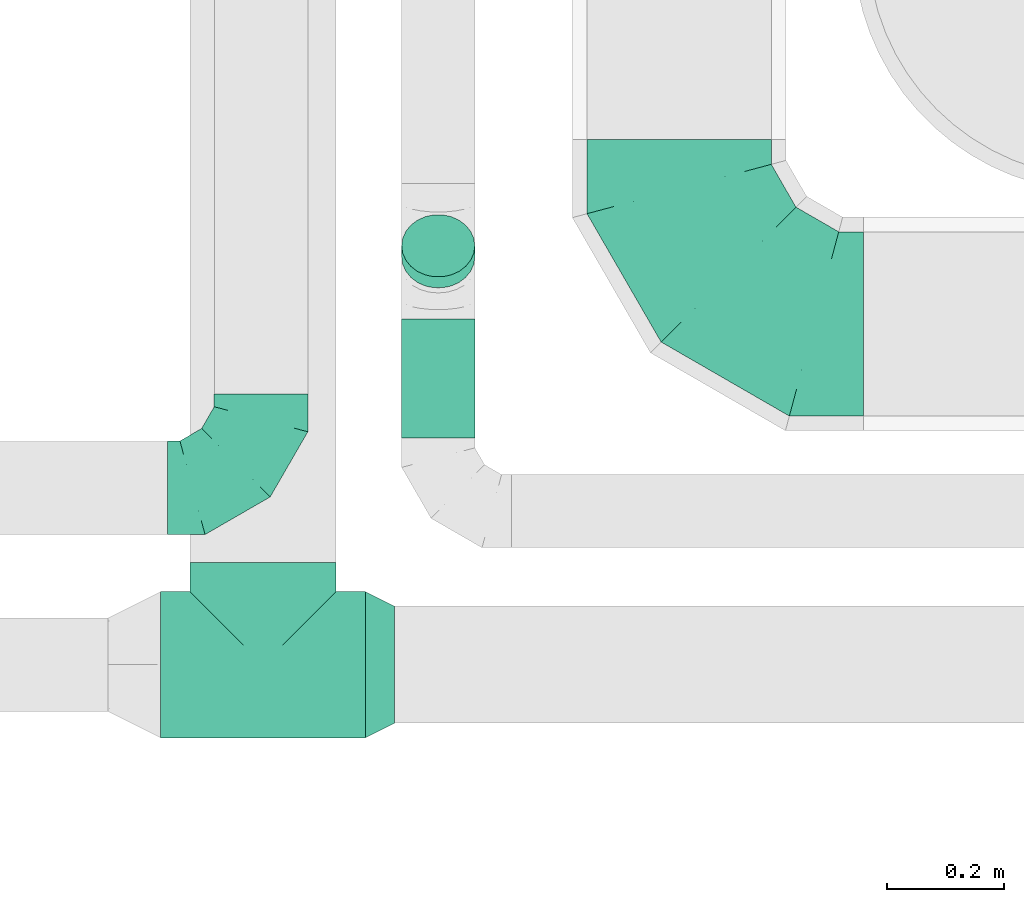
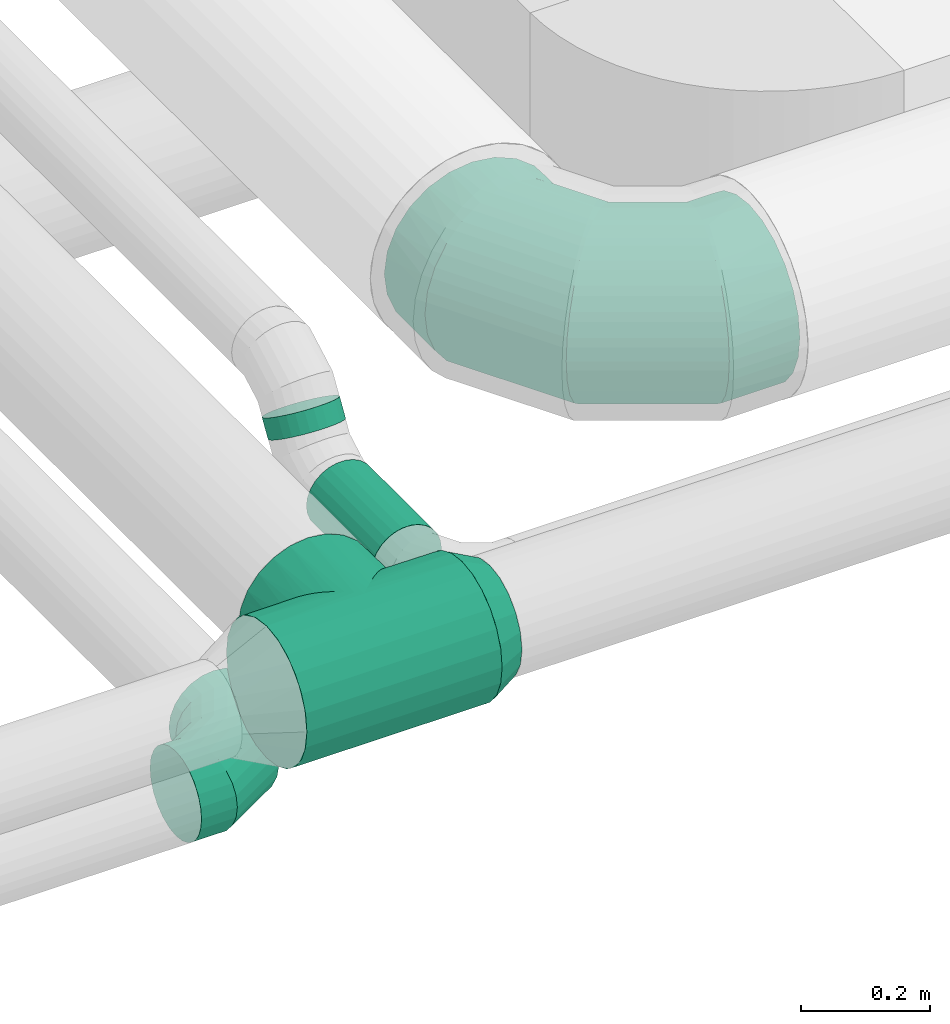
# One storey, part 35 of 92: 4 flow fittings, 2 flow segments.
"""IFC2X3 building model written with IfcOpenShell, lengths in millimetres."""

from ifc_helpers import new_model, entity, si_unit, converted_unit, derived_unit, direction, frame, origin, origin_2d_with_axis, place, context, subcontext, project, spatial, circle, extrude, faceted_brep, source, transform, mapped, material, type_object, type_shapes, element, save


model = new_model("IFC2X3")

# Units and contexts
model_context = context("Model", 3, precision=0.01, world=origin(), true_north=direction((6.12303176911189e-17, 1.0)))
body_context = subcontext(model_context, "Body", "Model", "MODEL_VIEW")
ifc_project = project(units=[si_unit("LENGTHUNIT", "METRE", prefix="MILLI"), si_unit("AREAUNIT", "SQUARE_METRE"), si_unit("VOLUMEUNIT", "CUBIC_METRE"), converted_unit("PLANEANGLEUNIT", "DEGREE", entity("IfcRatioMeasure", 0.0174532925199433), si_unit("PLANEANGLEUNIT", "RADIAN"), dimensions=[0, 0, 0, 0, 0, 0, 0]), si_unit("MASSUNIT", "GRAM", prefix="KILO"), derived_unit("MASSDENSITYUNIT", [(si_unit("MASSUNIT", "GRAM", prefix="KILO"), 1), (si_unit("LENGTHUNIT", "METRE"), -3)]), derived_unit("MOMENTOFINERTIAUNIT", [(si_unit("LENGTHUNIT", "METRE"), 4)]), si_unit("TIMEUNIT", "SECOND"), si_unit("FREQUENCYUNIT", "HERTZ"), si_unit("THERMODYNAMICTEMPERATUREUNIT", "DEGREE_CELSIUS"), derived_unit("THERMALTRANSMITTANCEUNIT", [(si_unit("MASSUNIT", "GRAM", prefix="KILO"), 1), (si_unit("THERMODYNAMICTEMPERATUREUNIT", "KELVIN"), -1), (si_unit("TIMEUNIT", "SECOND"), -3)]), derived_unit("VOLUMETRICFLOWRATEUNIT", [(si_unit("LENGTHUNIT", "METRE"), 3), (si_unit("TIMEUNIT", "SECOND"), -1)]), derived_unit("MASSFLOWRATEUNIT", [(si_unit("MASSUNIT", "GRAM", prefix="KILO"), 1), (si_unit("TIMEUNIT", "SECOND"), -1)]), derived_unit("ROTATIONALFREQUENCYUNIT", [(si_unit("TIMEUNIT", "SECOND"), -1)]), si_unit("ELECTRICCURRENTUNIT", "AMPERE"), si_unit("ELECTRICVOLTAGEUNIT", "VOLT"), si_unit("POWERUNIT", "WATT"), si_unit("FORCEUNIT", "NEWTON", prefix="KILO"), si_unit("ILLUMINANCEUNIT", "LUX"), si_unit("LUMINOUSFLUXUNIT", "LUMEN"), si_unit("LUMINOUSINTENSITYUNIT", "CANDELA"), derived_unit("USERDEFINED", [(si_unit("MASSUNIT", "GRAM", prefix="KILO"), -1), (si_unit("LENGTHUNIT", "METRE"), -2), (si_unit("TIMEUNIT", "SECOND"), 3), (si_unit("LUMINOUSFLUXUNIT", "LUMEN"), 1)]), derived_unit("LINEARVELOCITYUNIT", [(si_unit("LENGTHUNIT", "METRE"), 1), (si_unit("TIMEUNIT", "SECOND"), -1)]), si_unit("PRESSUREUNIT", "PASCAL"), derived_unit("USERDEFINED", [(si_unit("LENGTHUNIT", "METRE"), -2), (si_unit("MASSUNIT", "GRAM", prefix="KILO"), 1), (si_unit("TIMEUNIT", "SECOND"), -2)]), derived_unit("LINEARFORCEUNIT", [(si_unit("MASSUNIT", "GRAM", prefix="KILO"), 1), (si_unit("LENGTHUNIT", "METRE"), 1), (si_unit("TIMEUNIT", "SECOND"), -2), (si_unit("LENGTHUNIT", "METRE"), -1)]), derived_unit("PLANARFORCEUNIT", [(si_unit("MASSUNIT", "GRAM", prefix="KILO"), 1), (si_unit("LENGTHUNIT", "METRE"), 1), (si_unit("TIMEUNIT", "SECOND"), -2), (si_unit("LENGTHUNIT", "METRE"), -2)])], contexts=[model_context])

# Site, building, storey
site_placement = place(None, origin())
site = spatial("IfcSite", under=ifc_project, at=site_placement, CompositionType="ELEMENT")
building_placement = place(site_placement, origin())
building = spatial("IfcBuilding", under=site, at=building_placement, CompositionType="ELEMENT")
storey_placement = place(building_placement, frame((0.0, 0.0, 4200.0)))
storey = spatial("IfcBuildingStorey", under=building, at=storey_placement, CompositionType="ELEMENT", Elevation=4200.0)

# Flow segments
duct_segment_type = type_object("IfcDuctSegmentType", PredefinedType="NOTDEFINED")
flow_segment_1_placement = place(storey_placement, frame((8125.6, 11624.68, 3085.9)))
element("IfcFlowSegment", 1, at=flow_segment_1_placement, inside=storey, type_object=duct_segment_type, context=body_context, shape_type="SweptSolid", body=[
    extrude(circle(Radius=62.5, at=origin_2d_with_axis()), frame((64.1, 0.0, 64.1), z_axis=(0.0, 1.0, 0.0), x_axis=(1.0, 0.0, 0.0)), (0.0, 0.0, 1.0), 203.200433903821),
])
flow_segment_2_placement = place(storey_placement, frame((8125.6, 11879.56, 3175.37)))
element("IfcFlowSegment", 2, at=flow_segment_2_placement, inside=storey, type_object=duct_segment_type, context=body_context, shape_type="SweptSolid", body=[
    extrude(circle(Radius=62.5, at=origin_2d_with_axis()), frame((64.1, 54.87, 34.27), z_axis=(0.0, 0.522828553563816, 0.85243785907148), x_axis=(1.0, 0.0, 0.0)), (0.0, 0.0, 1.0), 36.0227294742767),
])

# Flow fittings
ifc_material = material()
duct_fitting_type_1 = type_object("IfcDuctFittingType", PredefinedType="NOTDEFINED", material=ifc_material)
shared_shape_1 = source(origin(), body_context, "Body", "Brep", [
    faceted_brep([(-160.0, 0.0, -80.0), (-160.0, -20.71, -77.27), (-160.0, -40.0, -69.28), (-160.0, -56.57, -56.57), (-160.0, -69.28, -40.0), (-160.0, -77.27, -20.71), (-160.0, -80.0, 0.0), (-160.0, -77.27, 20.71), (-160.0, -69.28, 40.0), (-160.0, -56.57, 56.57), (-160.0, -40.0, 69.28), (-160.0, -20.71, 77.27), (-160.0, 0.0, 80.0), (-160.0, 20.71, 77.27), (-160.0, 40.0, 69.28), (-160.0, 56.57, 56.57), (-160.0, 69.28, 40.0), (-160.0, 77.27, 20.71), (-160.0, 80.0, 0.0), (-160.0, 77.27, -20.71), (-160.0, 69.28, -40.0), (-160.0, 56.57, -56.57), (-160.0, 40.0, -69.28), (-160.0, 20.71, -77.27), (-122.68, 20.71, 77.27), (-127.85, 40.0, 69.28), (-117.13, 0.0, 80.0), (-132.29, 56.57, 56.57), (-137.83, 77.27, 20.71), (-138.56, 80.0, 0.0), (-135.69, 69.28, 40.0), (-135.69, 69.28, -40.0), (-132.29, 56.57, -56.57), (-137.83, 77.27, -20.71), (-122.68, 20.71, -77.27), (-117.13, 0.0, -80.0), (-127.85, 40.0, -69.28), (-111.58, -20.71, -77.27), (-106.41, -40.0, -69.28), (-101.97, -56.57, -56.57), (-98.56, -69.28, -40.0), (-96.42, -77.27, -20.71), (-95.69, -80.0, 0.0), (-96.42, -77.27, 20.71), (-98.56, -69.28, 40.0), (-101.97, -56.57, 56.57), (-106.41, -40.0, 69.28), (-111.58, -20.71, 77.27), (-58.03, 58.03, 77.27), (-72.15, 72.15, 69.28), (-42.87, 42.87, 80.0), (-84.28, 84.28, 56.57), (-93.59, 93.59, 40.0), (-99.44, 99.44, 20.71), (-101.44, 101.44, 0.0), (-99.44, 99.44, -20.71), (-93.59, 93.59, -40.0), (-84.28, 84.28, -56.57), (-58.03, 58.03, -77.27), (-42.87, 42.87, -80.0), (-72.15, 72.15, -69.28), (-27.71, 27.71, -77.27), (-13.59, 13.59, -69.28), (-1.46, 1.46, -56.57), (7.85, -7.85, -40.0), (13.7, -13.7, -20.71), (15.69, -15.69, 0.0), (13.7, -13.7, 20.71), (7.85, -7.85, 40.0), (-1.46, 1.46, 56.57), (-13.59, 13.59, 69.28), (-27.71, 27.71, 77.27), (-20.71, 122.68, 77.27), (-40.0, 127.85, 69.28), (0.0, 117.13, 80.0), (-56.57, 132.29, 56.57), (-69.28, 135.69, 40.0), (-77.27, 137.83, 20.71), (-80.0, 138.56, 0.0), (-77.27, 137.83, -20.71), (-69.28, 135.69, -40.0), (-56.57, 132.29, -56.57), (-20.71, 122.68, -77.27), (0.0, 117.13, -80.0), (-40.0, 127.85, -69.28), (20.71, 111.58, -77.27), (40.0, 106.41, -69.28), (56.57, 101.97, -56.57), (69.28, 98.56, -40.0), (77.27, 96.42, -20.71), (80.0, 95.69, 0.0), (77.27, 96.42, 20.71), (69.28, 98.56, 40.0), (56.57, 101.97, 56.57), (40.0, 106.41, 69.28), (20.71, 111.58, 77.27), (-20.71, 160.0, -77.27), (-40.0, 160.0, -69.28), (-56.57, 160.0, -56.57), (-69.28, 160.0, -40.0), (-77.27, 160.0, -20.71), (-80.0, 160.0, 0.0), (-77.27, 160.0, 20.71), (-69.28, 160.0, 40.0), (-56.57, 160.0, 56.57), (-40.0, 160.0, 69.28), (-20.71, 160.0, 77.27), (0.0, 160.0, 80.0), (20.71, 160.0, 77.27), (40.0, 160.0, 69.28), (56.57, 160.0, 56.57), (69.28, 160.0, 40.0), (77.27, 160.0, 20.71), (80.0, 160.0, 0.0), (77.27, 160.0, -20.71), (69.28, 160.0, -40.0), (56.57, 160.0, -56.57), (40.0, 160.0, -69.28), (20.71, 160.0, -77.27), (0.0, 160.0, -80.0)], [[[0, 1, 2, 3, 4, 5, 6, 7, 8, 9, 10, 11, 12, 13, 14, 15, 16, 17, 18, 19, 20, 21, 22, 23]], [[24, 25, 14, 13]], [[26, 24, 13, 12]], [[14, 25, 27, 15]], [[28, 29, 18, 17]], [[30, 28, 17, 16]], [[15, 27, 30, 16]], [[20, 31, 32, 21]], [[33, 31, 20, 19]], [[18, 29, 33, 19]], [[34, 35, 0, 23]], [[36, 34, 23, 22]], [[32, 36, 22, 21]], [[1, 0, 35, 37]], [[2, 1, 37, 38]], [[3, 2, 38, 39]], [[5, 4, 40, 41]], [[6, 5, 41, 42]], [[39, 40, 4, 3]], [[6, 42, 43, 7]], [[7, 43, 44, 8]], [[8, 44, 45, 9]], [[9, 45, 46, 10]], [[10, 46, 47, 11]], [[26, 12, 11, 47]], [[48, 49, 25, 24]], [[50, 48, 24, 26]], [[27, 25, 49, 51]], [[52, 53, 28, 30]], [[51, 52, 30, 27]], [[29, 28, 53, 54]], [[55, 56, 31, 33]], [[54, 55, 33, 29]], [[32, 31, 56, 57]], [[58, 59, 35, 34]], [[60, 58, 34, 36]], [[57, 60, 36, 32]], [[37, 35, 59, 61]], [[38, 37, 61, 62]], [[39, 38, 62, 63]], [[41, 40, 64, 65]], [[42, 41, 65, 66]], [[63, 64, 40, 39]], [[43, 42, 66, 67]], [[44, 43, 67, 68]], [[68, 69, 45, 44]], [[46, 45, 69, 70]], [[47, 46, 70, 71]], [[26, 47, 71, 50]], [[72, 73, 49, 48]], [[74, 72, 48, 50]], [[51, 49, 73, 75]], [[76, 77, 53, 52]], [[75, 76, 52, 51]], [[54, 53, 77, 78]], [[79, 80, 56, 55]], [[78, 79, 55, 54]], [[57, 56, 80, 81]], [[82, 83, 59, 58]], [[84, 82, 58, 60]], [[81, 84, 60, 57]], [[61, 59, 83, 85]], [[62, 61, 85, 86]], [[63, 62, 86, 87]], [[65, 64, 88, 89]], [[66, 65, 89, 90]], [[87, 88, 64, 63]], [[67, 66, 90, 91]], [[68, 67, 91, 92]], [[92, 93, 69, 68]], [[70, 69, 93, 94]], [[71, 70, 94, 95]], [[50, 71, 95, 74]], [[96, 97, 98, 99, 100, 101, 102, 103, 104, 105, 106, 107, 108, 109, 110, 111, 112, 113, 114, 115, 116, 117, 118, 119]], [[72, 74, 107, 106]], [[73, 72, 106, 105]], [[75, 73, 105, 104]], [[77, 76, 103, 102]], [[78, 77, 102, 101]], [[75, 104, 103, 76]], [[78, 101, 100, 79]], [[79, 100, 99, 80]], [[80, 99, 98, 81]], [[84, 97, 96, 82]], [[82, 96, 119, 83]], [[84, 81, 98, 97]], [[118, 117, 86, 85]], [[119, 118, 85, 83]], [[116, 87, 86, 117]], [[88, 115, 114, 89]], [[89, 114, 113, 90]], [[115, 88, 87, 116]], [[112, 111, 92, 91]], [[113, 112, 91, 90]], [[111, 110, 93, 92]], [[95, 94, 109, 108]], [[74, 95, 108, 107]], [[110, 109, 94, 93]]]),
])
type_shapes(duct_fitting_type_1, [shared_shape_1])
flow_fitting_1_placement = place(storey_placement, frame((7886.8, 11539.63, 2920.0)))
element("IfcFlowFitting", 3, at=flow_fitting_1_placement, inside=storey, type_object=duct_fitting_type_1, material=ifc_material, context=body_context, shape_type="MappedRepresentation", body=[
    mapped(shared_shape_1, transform((0.0, 0.0, 0.0), scale=1.0)),
])
duct_fitting_type_2 = type_object("IfcDuctFittingType", PredefinedType="NOTDEFINED", material=ifc_material)
shared_shape_2 = source(origin(), body_context, "Body", "Brep", [
    faceted_brep([(-315.0, 0.0, -157.5), (-315.0, -40.76, -152.13), (-315.0, -78.75, -136.4), (-315.0, -111.37, -111.37), (-315.0, -136.4, -78.75), (-315.0, -152.13, -40.76), (-315.0, -157.5, 0.0), (-315.0, -152.13, 40.76), (-315.0, -136.4, 78.75), (-315.0, -111.37, 111.37), (-315.0, -78.75, 136.4), (-315.0, -40.76, 152.13), (-315.0, 0.0, 157.5), (-315.0, 40.76, 152.13), (-315.0, 78.75, 136.4), (-315.0, 111.37, 111.37), (-315.0, 136.4, 78.75), (-315.0, 152.13, 40.76), (-315.0, 157.5, 0.0), (-315.0, 152.13, -40.76), (-315.0, 136.4, -78.75), (-315.0, 111.37, -111.37), (-315.0, 78.75, -136.4), (-315.0, 40.76, -152.13), (-241.52, 40.76, 152.13), (-251.7, 78.75, 136.4), (-230.6, 0.0, 157.5), (-260.44, 111.37, 111.37), (-271.36, 152.13, 40.76), (-272.8, 157.5, 0.0), (-267.14, 136.4, 78.75), (-267.14, 136.4, -78.75), (-260.44, 111.37, -111.37), (-271.36, 152.13, -40.76), (-241.52, 40.76, -152.13), (-230.6, 0.0, -157.5), (-251.7, 78.75, -136.4), (-219.67, -40.76, -152.13), (-209.5, -78.75, -136.4), (-200.75, -111.37, -111.37), (-194.05, -136.4, -78.75), (-189.83, -152.13, -40.76), (-188.39, -157.5, 0.0), (-189.83, -152.13, 40.76), (-194.05, -136.4, 78.75), (-200.75, -111.37, 111.37), (-209.5, -78.75, 136.4), (-219.67, -40.76, 152.13), (-114.25, 114.25, 152.13), (-142.05, 142.05, 136.4), (-84.4, 84.4, 157.5), (-165.93, 165.93, 111.37), (-184.25, 184.25, 78.75), (-195.77, 195.77, 40.76), (-199.7, 199.7, 0.0), (-195.77, 195.77, -40.76), (-184.25, 184.25, -78.75), (-165.93, 165.93, -111.37), (-114.25, 114.25, -152.13), (-84.4, 84.4, -157.5), (-142.05, 142.05, -136.4), (-54.56, 54.56, -152.13), (-26.75, 26.75, -136.4), (-2.88, 2.88, -111.37), (15.45, -15.45, -78.75), (26.97, -26.97, -40.76), (30.89, -30.89, 0.0), (26.97, -26.97, 40.76), (15.45, -15.45, 78.75), (-2.88, 2.88, 111.37), (-26.75, 26.75, 136.4), (-54.56, 54.56, 152.13), (-40.76, 241.52, 152.13), (-78.75, 251.7, 136.4), (0.0, 230.6, 157.5), (-111.37, 260.44, 111.37), (-136.4, 267.14, 78.75), (-152.13, 271.36, 40.76), (-157.5, 272.8, 0.0), (-152.13, 271.36, -40.76), (-136.4, 267.14, -78.75), (-111.37, 260.44, -111.37), (-40.76, 241.52, -152.13), (0.0, 230.6, -157.5), (-78.75, 251.7, -136.4), (40.76, 219.67, -152.13), (78.75, 209.5, -136.4), (111.37, 200.75, -111.37), (136.4, 194.05, -78.75), (152.13, 189.83, -40.76), (157.5, 188.39, 0.0), (152.13, 189.83, 40.76), (136.4, 194.05, 78.75), (111.37, 200.75, 111.37), (78.75, 209.5, 136.4), (40.76, 219.67, 152.13), (-40.76, 315.0, -152.13), (-78.75, 315.0, -136.4), (-111.37, 315.0, -111.37), (-136.4, 315.0, -78.75), (-152.13, 315.0, -40.76), (-157.5, 315.0, 0.0), (-152.13, 315.0, 40.76), (-136.4, 315.0, 78.75), (-111.37, 315.0, 111.37), (-78.75, 315.0, 136.4), (-40.76, 315.0, 152.13), (0.0, 315.0, 157.5), (40.76, 315.0, 152.13), (78.75, 315.0, 136.4), (111.37, 315.0, 111.37), (136.4, 315.0, 78.75), (152.13, 315.0, 40.76), (157.5, 315.0, 0.0), (152.13, 315.0, -40.76), (136.4, 315.0, -78.75), (111.37, 315.0, -111.37), (78.75, 315.0, -136.4), (40.76, 315.0, -152.13), (0.0, 315.0, -157.5)], [[[0, 1, 2, 3, 4, 5, 6, 7, 8, 9, 10, 11, 12, 13, 14, 15, 16, 17, 18, 19, 20, 21, 22, 23]], [[24, 25, 14, 13]], [[26, 24, 13, 12]], [[14, 25, 27, 15]], [[28, 29, 18, 17]], [[30, 28, 17, 16]], [[15, 27, 30, 16]], [[20, 31, 32, 21]], [[33, 31, 20, 19]], [[18, 29, 33, 19]], [[34, 35, 0, 23]], [[36, 34, 23, 22]], [[32, 36, 22, 21]], [[1, 0, 35, 37]], [[2, 1, 37, 38]], [[38, 39, 3, 2]], [[5, 4, 40, 41]], [[6, 5, 41, 42]], [[39, 40, 4, 3]], [[6, 42, 43, 7]], [[7, 43, 44, 8]], [[8, 44, 45, 9]], [[9, 45, 46, 10]], [[10, 46, 47, 11]], [[26, 12, 11, 47]], [[48, 49, 25, 24]], [[50, 48, 24, 26]], [[27, 25, 49, 51]], [[52, 53, 28, 30]], [[51, 52, 30, 27]], [[29, 28, 53, 54]], [[55, 56, 31, 33]], [[54, 55, 33, 29]], [[32, 31, 56, 57]], [[58, 59, 35, 34]], [[60, 58, 34, 36]], [[57, 60, 36, 32]], [[37, 35, 59, 61]], [[38, 37, 61, 62]], [[39, 38, 62, 63]], [[41, 40, 64, 65]], [[42, 41, 65, 66]], [[63, 64, 40, 39]], [[43, 42, 66, 67]], [[44, 43, 67, 68]], [[68, 69, 45, 44]], [[46, 45, 69, 70]], [[47, 46, 70, 71]], [[26, 47, 71, 50]], [[72, 73, 49, 48]], [[74, 72, 48, 50]], [[51, 49, 73, 75]], [[76, 77, 53, 52]], [[75, 76, 52, 51]], [[54, 53, 77, 78]], [[79, 80, 56, 55]], [[78, 79, 55, 54]], [[57, 56, 80, 81]], [[82, 83, 59, 58]], [[84, 82, 58, 60]], [[81, 84, 60, 57]], [[61, 59, 83, 85]], [[62, 61, 85, 86]], [[63, 62, 86, 87]], [[65, 64, 88, 89]], [[66, 65, 89, 90]], [[87, 88, 64, 63]], [[67, 66, 90, 91]], [[68, 67, 91, 92]], [[92, 93, 69, 68]], [[70, 69, 93, 94]], [[71, 70, 94, 95]], [[50, 71, 95, 74]], [[96, 97, 98, 99, 100, 101, 102, 103, 104, 105, 106, 107, 108, 109, 110, 111, 112, 113, 114, 115, 116, 117, 118, 119]], [[106, 105, 73, 72]], [[107, 106, 72, 74]], [[75, 73, 105, 104]], [[77, 76, 103, 102]], [[78, 77, 102, 101]], [[104, 103, 76, 75]], [[78, 101, 100, 79]], [[79, 100, 99, 80]], [[98, 81, 80, 99]], [[84, 97, 96, 82]], [[82, 96, 119, 83]], [[97, 84, 81, 98]], [[83, 119, 118, 85]], [[85, 118, 117, 86]], [[116, 87, 86, 117]], [[88, 115, 114, 89]], [[89, 114, 113, 90]], [[115, 88, 87, 116]], [[91, 90, 113, 112]], [[92, 91, 112, 111]], [[111, 110, 93, 92]], [[95, 94, 109, 108]], [[74, 95, 108, 107]], [[110, 109, 94, 93]]]),
])
type_shapes(duct_fitting_type_2, [shared_shape_2])
flow_fitting_2_placement = place(storey_placement, frame((8601.41, 11819.68, 3292.5), z_axis=(0.0, 0.0, 1.0), x_axis=(0.0, -1.0, 0.0)))
element("IfcFlowFitting", 4, at=flow_fitting_2_placement, inside=storey, type_object=duct_fitting_type_2, material=ifc_material, context=body_context, shape_type="MappedRepresentation", body=[
    mapped(shared_shape_2, transform((0.0, 0.0, 0.0), scale=1.0)),
])
duct_fitting_type_3 = type_object("IfcDuctFittingType", PredefinedType="NOTDEFINED", material=ifc_material)
shared_shape_3 = source(origin(), body_context, "Body", "Brep", [
    faceted_brep([(50.0, -73.47, -101.13), (50.0, -38.63, -118.88), (50.0, 0.0, -125.0), (50.0, 38.63, -118.88), (50.0, 73.47, -101.13), (50.0, 101.13, -73.47), (50.0, 118.88, -38.63), (50.0, 125.0, 0.0), (50.0, 118.88, 38.63), (50.0, 101.13, 73.47), (50.0, 73.47, 101.13), (50.0, 38.63, 118.88), (50.0, 0.0, 125.0), (50.0, -38.63, 118.88), (50.0, -73.47, 101.13), (50.0, -101.13, 73.47), (50.0, -118.88, 38.63), (50.0, -125.0, 0.0), (50.0, -118.88, -38.63), (50.0, -101.13, -73.47), (0.0, 30.9, -95.11), (0.0, 0.0, -100.0), (0.0, -30.9, -95.11), (0.0, -58.78, -80.9), (0.0, -80.9, -58.78), (0.0, -95.11, -30.9), (0.0, -100.0, 0.0), (0.0, -95.11, 30.9), (0.0, -80.9, 58.78), (0.0, -58.78, 80.9), (0.0, -30.9, 95.11), (0.0, 0.0, 100.0), (0.0, 30.9, 95.11), (0.0, 58.78, 80.9), (0.0, 80.9, 58.78), (0.0, 95.11, 30.9), (0.0, 100.0, 0.0), (0.0, 95.11, -30.9), (0.0, 80.9, -58.78), (0.0, 58.78, -80.9)], [[[0, 1, 2, 3, 4, 5, 6, 7, 8, 9, 10, 11, 12, 13, 14, 15, 16, 17, 18, 19]], [[20, 21, 22, 23, 24, 25, 26, 27, 28, 29, 30, 31, 32, 33, 34, 35, 36, 37, 38, 39]], [[35, 34, 9, 8]], [[36, 35, 8, 7]], [[34, 33, 10, 9]], [[10, 33, 32, 11]], [[11, 32, 31, 12]], [[30, 29, 14, 13]], [[31, 30, 13, 12]], [[29, 28, 15, 14]], [[15, 28, 27, 16]], [[16, 27, 26, 17]], [[25, 24, 19, 18]], [[26, 25, 18, 17]], [[24, 23, 0, 19]], [[0, 23, 22, 1]], [[1, 22, 21, 2]], [[20, 39, 4, 3]], [[21, 20, 3, 2]], [[39, 38, 5, 4]], [[5, 38, 37, 6]], [[6, 37, 36, 7]]]),
])
type_shapes(duct_fitting_type_3, [shared_shape_3])
flow_fitting_3_placement = place(storey_placement, frame((8115.09, 11237.19, 3300.0), z_axis=(0.0, 0.0, 1.0), x_axis=(-1.0, 0.0, 0.0)))
element("IfcFlowFitting", 5, at=flow_fitting_3_placement, inside=storey, type_object=duct_fitting_type_3, material=ifc_material, context=body_context, shape_type="MappedRepresentation", body=[
    mapped(shared_shape_3, transform((0.0, 0.0, 0.0), scale=1.0)),
])
duct_fitting_type_4 = type_object("IfcDuctFittingType", PredefinedType="NOTDEFINED", material=ifc_material)
shared_shape_4 = source(origin(), body_context, "Body", "Brep", [
    faceted_brep([(22.44, -22.44, -122.97), (175.0, 0.0, -125.0), (175.0, -32.35, -120.74), (175.0, -62.5, -108.25), (75.83, -75.83, -99.37), (65.72, -65.72, -106.33), (175.0, -88.39, -88.39), (55.24, -55.24, -112.13), (11.24, -11.24, -124.49), (0.0, 0.0, -125.0), (-11.24, -11.24, -124.49), (-175.0, 0.0, -125.0), (44.49, -44.49, -116.81), (33.54, -33.54, -120.42), (175.0, -108.25, -62.5), (102.86, -102.86, -71.03), (175.0, -120.74, -32.35), (116.36, -116.36, -45.66), (175.0, -114.5, -47.43), (123.99, -123.99, -15.84), (175.0, -125.0, 0.0), (125.0, -125.0, 0.0), (-123.99, -123.99, -15.84), (-125.0, -125.0, 0.0), (-175.0, -125.0, 0.0), (175.0, -122.87, -16.18), (110.21, -110.21, -58.98), (121.05, -121.05, -31.19), (94.55, -94.55, -81.76), (85.49, -85.49, -91.2), (123.99, -123.99, 15.84), (-123.99, -123.99, 15.84), (175.0, -114.5, 47.43), (175.0, -108.25, 62.5), (110.21, -110.21, 58.98), (175.0, -120.74, 32.35), (121.05, -121.05, 31.19), (175.0, -122.87, 16.18), (102.86, -102.86, 71.03), (175.0, -88.39, 88.39), (116.36, -116.36, 45.66), (94.55, -94.55, 81.76), (85.49, -85.49, 91.2), (75.83, -75.83, 99.37), (65.72, -65.72, 106.33), (175.0, -62.5, 108.25), (55.24, -55.24, 112.13), (175.0, -32.35, 120.74), (22.44, -22.44, 122.97), (175.0, 0.0, 125.0), (44.49, -44.49, 116.81), (33.54, -33.54, 120.42), (11.24, -11.24, 124.49), (0.0, 0.0, 125.0), (-11.24, -11.24, 124.49), (-175.0, 0.0, 125.0), (32.35, -175.0, -120.74), (62.5, -175.0, -108.25), (88.39, -175.0, -88.39), (108.25, -175.0, -62.5), (114.5, -175.0, -47.43), (120.74, -175.0, -32.35), (122.87, -175.0, -16.18), (125.0, -175.0, 0.0), (122.87, -175.0, 16.18), (120.74, -175.0, 32.35), (114.5, -175.0, 47.43), (108.25, -175.0, 62.5), (88.39, -175.0, 88.39), (62.5, -175.0, 108.25), (32.35, -175.0, 120.74), (0.0, -175.0, 125.0), (-32.35, -175.0, 120.74), (-62.5, -175.0, 108.25), (-88.39, -175.0, 88.39), (-108.25, -175.0, 62.5), (-114.5, -175.0, 47.43), (-120.74, -175.0, 32.35), (-122.87, -175.0, 16.18), (-125.0, -175.0, 0.0), (-122.87, -175.0, -16.18), (-120.74, -175.0, -32.35), (-114.5, -175.0, -47.43), (-108.25, -175.0, -62.5), (-88.39, -175.0, -88.39), (-62.5, -175.0, -108.25), (-32.35, -175.0, -120.74), (0.0, -175.0, -125.0), (-22.44, -22.44, -122.97), (-75.83, -75.83, -99.37), (-65.72, -65.72, -106.33), (-55.24, -55.24, -112.13), (-44.49, -44.49, -116.81), (-33.54, -33.54, -120.42), (-102.86, -102.86, -71.03), (-116.36, -116.36, -45.66), (-110.21, -110.21, -58.98), (-121.05, -121.05, -31.19), (-94.55, -94.55, -81.76), (-85.49, -85.49, -91.2), (-110.21, -110.21, 58.98), (-121.05, -121.05, 31.19), (-102.86, -102.86, 71.03), (-116.36, -116.36, 45.66), (-94.55, -94.55, 81.76), (-85.49, -85.49, 91.2), (-75.83, -75.83, 99.37), (-65.72, -65.72, 106.33), (-55.24, -55.24, 112.13), (-22.44, -22.44, 122.97), (-44.49, -44.49, 116.81), (-33.54, -33.54, 120.42), (-175.0, -32.35, -120.74), (-175.0, -62.5, -108.25), (-175.0, -88.39, -88.39), (-175.0, -108.25, -62.5), (-175.0, -114.5, -47.43), (-175.0, -120.74, -32.35), (-175.0, -122.87, -16.18), (-175.0, -122.87, 16.18), (-175.0, -120.74, 32.35), (-175.0, -114.5, 47.43), (-175.0, -108.25, 62.5), (-175.0, -88.39, 88.39), (-175.0, -62.5, 108.25), (-175.0, -32.35, 120.74), (-175.0, 32.35, 120.74), (-175.0, 62.5, 108.25), (-175.0, 88.39, 88.39), (-175.0, 108.25, 62.5), (-175.0, 120.74, 32.35), (-175.0, 125.0, 0.0), (-175.0, 120.74, -32.35), (-175.0, 108.25, -62.5), (-175.0, 88.39, -88.39), (-175.0, 62.5, -108.25), (-175.0, 32.35, -120.74), (175.0, 32.35, -120.74), (175.0, 62.5, -108.25), (175.0, 88.39, -88.39), (175.0, 108.25, -62.5), (175.0, 120.74, -32.35), (175.0, 125.0, 0.0), (175.0, 120.74, 32.35), (175.0, 108.25, 62.5), (175.0, 88.39, 88.39), (175.0, 62.5, 108.25), (175.0, 32.35, 120.74)], [[[0, 1, 2]], [[3, 4, 5]], [[4, 3, 6]], [[2, 3, 7]], [[5, 7, 3]], [[8, 9, 1]], [[9, 10, 11]], [[0, 8, 1]], [[12, 13, 2]], [[7, 12, 2]], [[0, 2, 13]], [[14, 15, 6]], [[16, 17, 18]], [[19, 20, 21]], [[22, 23, 24]], [[20, 19, 25]], [[26, 18, 17]], [[27, 16, 25]], [[28, 29, 6]], [[15, 28, 6]], [[27, 25, 19]], [[26, 14, 18]], [[27, 17, 16]], [[15, 14, 26]], [[6, 29, 4]], [[30, 21, 20]], [[23, 31, 24]], [[32, 33, 34]], [[35, 36, 37]], [[38, 33, 39]], [[40, 35, 32]], [[30, 37, 36]], [[40, 36, 35]], [[38, 34, 33]], [[41, 38, 39]], [[32, 34, 40]], [[30, 20, 37]], [[39, 42, 41]], [[42, 39, 43]], [[44, 43, 45]], [[46, 45, 47]], [[45, 46, 44]], [[39, 45, 43]], [[48, 47, 49]], [[50, 46, 47]], [[51, 50, 47]], [[52, 48, 49]], [[53, 52, 49]], [[54, 53, 55]], [[51, 47, 48]], [[56, 57, 58, 59, 60, 61, 62, 63, 64, 65, 66, 67, 68, 69, 70, 71, 72, 73, 74, 75, 76, 77, 78, 79, 80, 81, 82, 83, 84, 85, 86, 87]], [[48, 71, 70]], [[69, 43, 44]], [[43, 69, 68]], [[70, 69, 46]], [[44, 46, 69]], [[52, 53, 71]], [[48, 52, 71]], [[50, 51, 70]], [[46, 50, 70]], [[48, 70, 51]], [[67, 38, 68]], [[65, 40, 66]], [[30, 63, 21]], [[63, 30, 64]], [[34, 66, 40]], [[36, 65, 64]], [[41, 42, 68]], [[38, 41, 68]], [[36, 64, 30]], [[34, 67, 66]], [[36, 40, 65]], [[38, 67, 34]], [[68, 42, 43]], [[19, 21, 63]], [[60, 59, 26]], [[62, 61, 27]], [[15, 59, 58]], [[17, 61, 60]], [[19, 62, 27]], [[17, 27, 61]], [[15, 26, 59]], [[28, 15, 58]], [[60, 26, 17]], [[19, 63, 62]], [[58, 29, 28]], [[29, 58, 4]], [[5, 4, 57]], [[7, 57, 56]], [[57, 7, 5]], [[58, 57, 4]], [[0, 56, 87]], [[12, 7, 56]], [[13, 12, 56]], [[8, 0, 87]], [[9, 8, 87]], [[13, 56, 0]], [[88, 87, 86]], [[85, 89, 90]], [[89, 85, 84]], [[86, 85, 91]], [[90, 91, 85]], [[10, 9, 87]], [[88, 10, 87]], [[92, 93, 86]], [[91, 92, 86]], [[88, 86, 93]], [[83, 94, 84]], [[81, 95, 82]], [[22, 79, 23]], [[79, 22, 80]], [[96, 82, 95]], [[97, 81, 80]], [[98, 99, 84]], [[94, 98, 84]], [[97, 80, 22]], [[96, 83, 82]], [[97, 95, 81]], [[94, 83, 96]], [[84, 99, 89]], [[31, 23, 79]], [[76, 75, 100]], [[77, 101, 78]], [[102, 75, 74]], [[103, 77, 76]], [[31, 78, 101]], [[103, 101, 77]], [[102, 100, 75]], [[104, 102, 74]], [[76, 100, 103]], [[31, 79, 78]], [[74, 105, 104]], [[105, 74, 106]], [[107, 106, 73]], [[108, 73, 72]], [[73, 108, 107]], [[74, 73, 106]], [[109, 72, 71]], [[110, 108, 72]], [[111, 110, 72]], [[54, 109, 71]], [[53, 54, 71]], [[111, 72, 109]], [[11, 112, 113, 114, 115, 116, 117, 118, 24, 119, 120, 121, 122, 123, 124, 125, 55, 126, 127, 128, 129, 130, 131, 132, 133, 134, 135, 136]], [[137, 138, 139, 140, 141, 142, 143, 144, 145, 146, 147, 49, 47, 45, 39, 33, 32, 35, 37, 20, 25, 16, 18, 14, 6, 3, 2, 1]], [[53, 49, 147, 126, 55]], [[127, 126, 147, 146]], [[146, 145, 128, 127]], [[129, 128, 145, 144]], [[130, 129, 144, 143]], [[131, 130, 143, 142]], [[132, 131, 142, 141]], [[133, 132, 141, 140]], [[140, 139, 134, 133]], [[135, 134, 139, 138]], [[136, 135, 138, 137]], [[9, 11, 136, 137, 1]], [[93, 92, 112]], [[88, 93, 112]], [[10, 88, 11]], [[88, 112, 11]], [[112, 92, 91]], [[112, 91, 113]], [[113, 90, 89]], [[90, 113, 91]], [[113, 89, 114]], [[98, 94, 114]], [[99, 98, 114]], [[95, 117, 116]], [[95, 97, 117]], [[95, 116, 96]], [[94, 96, 115]], [[116, 115, 96]], [[115, 114, 94]], [[22, 24, 118]], [[118, 117, 97]], [[118, 97, 22]], [[99, 114, 89]], [[101, 103, 120]], [[102, 104, 123]], [[100, 102, 122]], [[101, 119, 31]], [[100, 122, 121]], [[100, 121, 103]], [[24, 31, 119]], [[120, 119, 101]], [[103, 121, 120]], [[102, 123, 122]], [[104, 105, 123]], [[110, 111, 125]], [[108, 110, 125]], [[109, 54, 55]], [[111, 109, 125]], [[106, 107, 124]], [[106, 124, 123]], [[108, 124, 107]], [[108, 125, 124]], [[109, 55, 125]], [[106, 123, 105]]]),
])
type_shapes(duct_fitting_type_4, [shared_shape_4])
flow_fitting_4_placement = place(storey_placement, frame((7890.09, 11237.19, 3300.0), z_axis=(0.0, 0.0, 1.0), x_axis=(-1.0, 0.0, 0.0)))
element("IfcFlowFitting", 6, at=flow_fitting_4_placement, inside=storey, type_object=duct_fitting_type_4, material=ifc_material, context=body_context, shape_type="MappedRepresentation", body=[
    mapped(shared_shape_4, transform((0.0, 0.0, 0.0), scale=1.0)),
])

save(model, "model.ifc")
